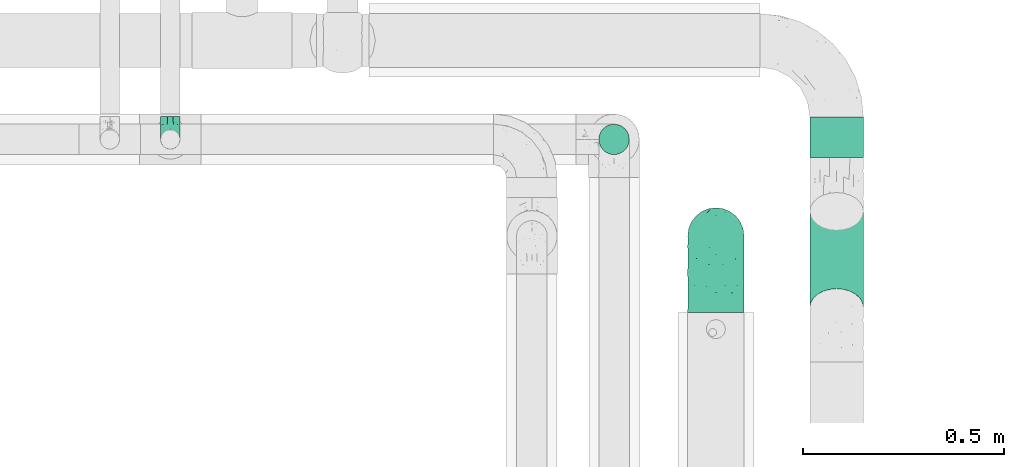
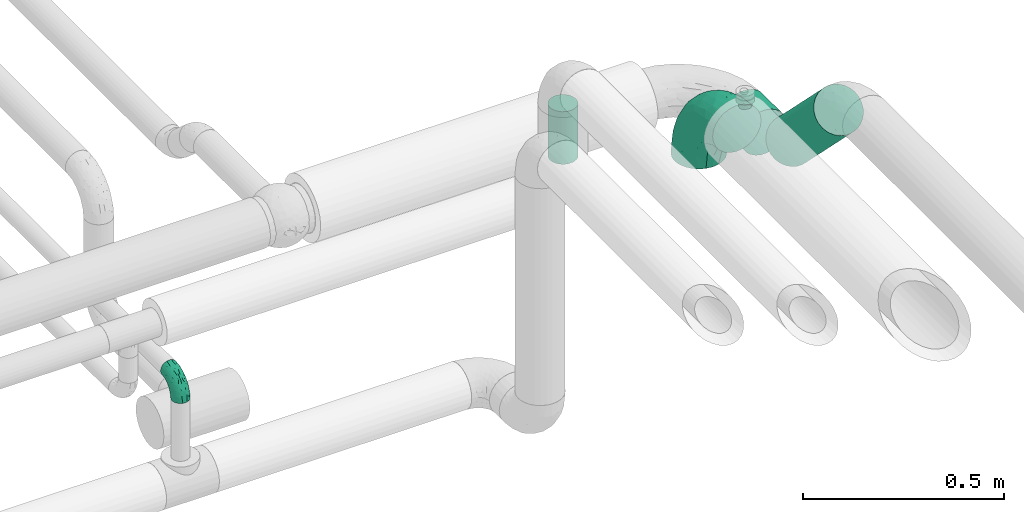
# One storey, part 558 of 827: 3 flow segments, 2 flow fittings.
"""IFC2X3 building model written with IfcOpenShell, lengths in millimetres."""

from ifc_helpers import new_model, entity, si_unit, converted_unit, derived_unit, direction, frame, origin, origin_2d_with_axis, place, context, subcontext, project, spatial, circle, extrude, faceted_brep, source, transform, mapped, material, type_object, type_shapes, element, save


model = new_model("IFC2X3")

# Units and contexts
model_context = context("Model", 3, precision=0.01, world=origin(), true_north=direction((6.12303176911189e-17, 1.0)))
body_context = subcontext(model_context, "Body", "Model", "MODEL_VIEW")
ifc_project = project(units=[si_unit("LENGTHUNIT", "METRE", prefix="MILLI"), si_unit("AREAUNIT", "SQUARE_METRE"), si_unit("VOLUMEUNIT", "CUBIC_METRE"), converted_unit("PLANEANGLEUNIT", "DEGREE", entity("IfcRatioMeasure", 0.0174532925199433), si_unit("PLANEANGLEUNIT", "RADIAN"), dimensions=[0, 0, 0, 0, 0, 0, 0]), si_unit("MASSUNIT", "GRAM", prefix="KILO"), derived_unit("MASSDENSITYUNIT", [(si_unit("MASSUNIT", "GRAM", prefix="KILO"), 1), (si_unit("LENGTHUNIT", "METRE"), -3)]), derived_unit("MOMENTOFINERTIAUNIT", [(si_unit("LENGTHUNIT", "METRE"), 4)]), si_unit("TIMEUNIT", "SECOND"), si_unit("FREQUENCYUNIT", "HERTZ"), si_unit("THERMODYNAMICTEMPERATUREUNIT", "DEGREE_CELSIUS"), derived_unit("THERMALTRANSMITTANCEUNIT", [(si_unit("MASSUNIT", "GRAM", prefix="KILO"), 1), (si_unit("THERMODYNAMICTEMPERATUREUNIT", "KELVIN"), -1), (si_unit("TIMEUNIT", "SECOND"), -3)]), derived_unit("VOLUMETRICFLOWRATEUNIT", [(si_unit("LENGTHUNIT", "METRE"), 3), (si_unit("TIMEUNIT", "SECOND"), -1)]), derived_unit("MASSFLOWRATEUNIT", [(si_unit("MASSUNIT", "GRAM", prefix="KILO"), 1), (si_unit("TIMEUNIT", "SECOND"), -1)]), derived_unit("ROTATIONALFREQUENCYUNIT", [(si_unit("TIMEUNIT", "SECOND"), -1)]), si_unit("ELECTRICCURRENTUNIT", "AMPERE"), si_unit("ELECTRICVOLTAGEUNIT", "VOLT"), si_unit("POWERUNIT", "WATT"), si_unit("FORCEUNIT", "NEWTON", prefix="KILO"), si_unit("ILLUMINANCEUNIT", "LUX"), si_unit("LUMINOUSFLUXUNIT", "LUMEN"), si_unit("LUMINOUSINTENSITYUNIT", "CANDELA"), derived_unit("USERDEFINED", [(si_unit("MASSUNIT", "GRAM", prefix="KILO"), -1), (si_unit("LENGTHUNIT", "METRE"), -2), (si_unit("TIMEUNIT", "SECOND"), 3), (si_unit("LUMINOUSFLUXUNIT", "LUMEN"), 1)]), derived_unit("LINEARVELOCITYUNIT", [(si_unit("LENGTHUNIT", "METRE"), 1), (si_unit("TIMEUNIT", "SECOND"), -1)]), si_unit("PRESSUREUNIT", "PASCAL"), derived_unit("USERDEFINED", [(si_unit("LENGTHUNIT", "METRE"), -2), (si_unit("MASSUNIT", "GRAM", prefix="KILO"), 1), (si_unit("TIMEUNIT", "SECOND"), -2)]), derived_unit("LINEARFORCEUNIT", [(si_unit("MASSUNIT", "GRAM", prefix="KILO"), 1), (si_unit("LENGTHUNIT", "METRE"), 1), (si_unit("TIMEUNIT", "SECOND"), -2), (si_unit("LENGTHUNIT", "METRE"), -1)]), derived_unit("PLANARFORCEUNIT", [(si_unit("MASSUNIT", "GRAM", prefix="KILO"), 1), (si_unit("LENGTHUNIT", "METRE"), 1), (si_unit("TIMEUNIT", "SECOND"), -2), (si_unit("LENGTHUNIT", "METRE"), -2)])], contexts=[model_context])

# Site, building, storey
site_placement = place(None, origin())
site = spatial("IfcSite", under=ifc_project, at=site_placement, CompositionType="ELEMENT")
building_placement = place(site_placement, origin())
building = spatial("IfcBuilding", under=site, at=building_placement, CompositionType="ELEMENT")
storey_placement = place(building_placement, frame((0.0, 0.0, 28200.0)))
storey = spatial("IfcBuildingStorey", under=building, at=storey_placement, Name="08", CompositionType="ELEMENT", Elevation=28200.0)

# Flow segments
pipe_segment_type_1 = type_object("IfcPipeSegmentType", PredefinedType="NOTDEFINED")
flow_segment_1_placement = place(storey_placement, frame((27351.94, 12025.46, 3031.9)))
element("IfcFlowSegment", 1, at=flow_segment_1_placement, inside=storey, type_object=pipe_segment_type_1, context=body_context, shape_type="SweptSolid", body=[
    extrude(circle(Radius=66.5, at=origin_2d_with_axis()), frame((68.1, 0.0, 68.1), z_axis=(0.0, 1.0, 0.0), x_axis=(-1.0, 0.0, 0.0)), (0.0, 0.0, 1.0), 100.109244825128),
])
flow_segment_2_placement = place(storey_placement, frame((27351.94, 11603.79, 3107.03)))
element("IfcFlowSegment", 2, at=flow_segment_2_placement, inside=storey, type_object=pipe_segment_type_1, context=body_context, shape_type="SweptSolid", body=[
    extrude(circle(Radius=66.5, at=origin_2d_with_axis()), frame((68.1, 48.62, 287.32), z_axis=(0.0, 0.707106781186515, -0.70710678118658), x_axis=(-1.0, 0.0, 0.0)), (0.0, 0.0, 1.0), 337.573593128828),
])
pipe_segment_type_2 = type_object("IfcPipeSegmentType", PredefinedType="NOTDEFINED")
flow_segment_3_placement = place(storey_placement, frame((26828.29, 12030.66, 3195.0)))
element("IfcFlowSegment", 3, at=flow_segment_3_placement, inside=storey, type_object=pipe_segment_type_2, context=body_context, shape_type="SweptSolid", body=[
    extrude(circle(Radius=37.75, at=origin_2d_with_axis()), frame((39.35, 39.35, 0.0), z_axis=(0.0, 0.0, 1.0), x_axis=(-1.0, 0.0, 0.0)), (0.0, 0.0, 1.0), 160.000000000016),
])

# Flow fittings
ifc_material = material()
pipe_fitting_type_1 = type_object("IfcPipeFittingType", Name="ADSK_1", PredefinedType="NOTDEFINED", material=ifc_material)
shared_shape_1 = source(origin(), body_context, "Body", "Brep", [
    faceted_brep([(-57.0, 12.07, -20.91), (-57.0, 6.25, -23.33), (-57.0, 0.0, -24.15), (-57.0, -6.25, -23.33), (-57.0, -12.08, -20.91), (-57.0, -17.08, -17.08), (-57.0, -20.91, -12.08), (-57.0, -23.33, -6.25), (-57.0, -24.15, 0.0), (-57.0, -23.33, 6.25), (-57.0, -20.91, 12.07), (-57.0, -17.08, 17.08), (-57.0, -12.08, 20.91), (-57.0, -6.25, 23.33), (-57.0, 0.0, 24.15), (-57.0, 6.25, 23.33), (-57.0, 12.07, 20.91), (-57.0, 17.08, 17.08), (-57.0, 20.91, 12.07), (-57.0, 23.33, 6.25), (-57.0, 24.15, 0.0), (-57.0, 23.33, -6.25), (-57.0, 20.91, -12.08), (-57.0, 17.08, -17.08), (0.0, 57.0, -24.15), (-6.25, 57.0, -23.33), (-12.07, 57.0, -20.91), (-17.08, 57.0, -17.08), (-20.91, 57.0, -12.08), (-23.33, 57.0, -6.25), (-24.15, 57.0, 0.0), (-23.33, 57.0, 6.25), (-20.91, 57.0, 12.07), (-17.08, 57.0, 17.08), (-12.07, 57.0, 20.91), (-6.25, 57.0, 23.33), (0.0, 57.0, 24.15), (6.25, 57.0, 23.33), (12.08, 57.0, 20.91), (17.08, 57.0, 17.08), (20.91, 57.0, 12.07), (23.33, 57.0, 6.25), (24.15, 57.0, 0.0), (23.33, 57.0, -6.25), (20.91, 57.0, -12.08), (17.08, 57.0, -17.08), (12.08, 57.0, -20.91), (6.25, 57.0, -23.33), (14.9, 21.14, 6.17), (13.61, 24.64, 12.48), (6.23, 8.95, 8.98), (-41.47, -21.06, 0.0), (-41.92, -18.38, 13.72), (-24.64, -13.61, 12.48), (-37.37, -13.24, 18.15), (-6.8, -4.93, 8.18), (-21.76, -15.19, 6.22), (-12.78, -9.18, 0.0), (-37.73, -20.51, 7.75), (-7.38, 7.38, 20.24), (-23.37, -4.26, 20.42), (-11.9, -3.19, 15.86), (-42.14, -8.7, 21.82), (13.24, 37.37, 18.15), (9.33, 23.53, 16.85), (4.26, 23.37, 20.42), (2.77, 10.92, 15.55), (-29.46, 0.91, 23.52), (-44.13, 20.56, 15.69), (-39.25, 26.33, 10.88), (-49.02, 22.92, 9.96), (-34.58, 23.87, 17.15), (-15.8, 6.8, 22.81), (-8.67, 20.47, 23.88), (-18.12, 12.9, 24.08), (-48.29, 14.92, 19.65), (-44.06, -2.85, 23.78), (-9.23, 48.95, 22.58), (-3.78, 42.74, 24.07), (-40.34, 4.26, 24.09), (-44.02, 26.14, 5.46), (-44.04, 9.88, 22.74), (-4.95, 16.87, 22.52), (-2.75, 1.43, 12.5), (-25.48, 40.98, 10.71), (20.51, 37.73, 7.75), (18.38, 41.92, 13.72), (8.7, 42.14, 21.82), (-25.95, -17.97, 0.0), (2.85, 44.06, 23.78), (21.06, 41.47, 0.0), (17.97, 25.95, 0.0), (-24.04, -9.27, 17.13), (-33.26, 33.26, 5.86), (-28.55, 40.57, 0.0), (-40.57, 28.55, 0.0), (-25.29, 47.19, 4.06), (-27.01, 31.1, 16.77), (-15.7, 43.95, 19.9), (-20.27, 45.22, 15.61), (-30.53, 31.98, 12.64), (-11.28, 38.33, 22.92), (-9.97, 27.88, 24.09), (-20.15, 30.26, 21.25), (-31.25, 11.75, 23.64), (-28.75, 7.23, 24.15), (-29.53, 18.06, 22.27), (-28.44, 24.21, 20.02), (-37.55, 17.7, 20.26), (-15.88, 29.25, 22.99), (-20.82, 20.82, 23.44), (-0.91, 29.46, 23.52), (-13.5, -7.67, 12.04), (1.49, 1.56, 5.16), (8.86, 10.35, 4.59), (0.38, -0.38, 0.0), (9.18, 12.78, 0.0), (-37.37, -13.24, -18.15), (8.86, 10.35, -4.59), (-45.22, 20.27, -15.61), (-43.95, 15.7, -19.9), (-38.33, 11.28, -22.92), (-48.95, 9.23, -22.58), (-47.19, 25.29, -4.06), (-33.26, 33.26, -5.86), (18.38, 41.92, -13.72), (-30.26, 20.15, -21.25), (2.85, 44.06, -23.78), (-4.26, 40.34, -24.09), (-40.98, 25.48, -10.71), (-41.92, -18.38, -13.72), (9.25, 23.5, -16.92), (4.26, 23.37, -20.42), (13.24, 37.37, -18.15), (-37.73, -20.51, -7.75), (-11.75, 31.25, -23.64), (-7.23, 28.75, -24.15), (-12.9, 18.12, -24.08), (8.7, 42.14, -21.82), (-44.06, -2.85, -23.78), (-6.8, 15.8, -22.81), (-20.47, 8.67, -23.88), (-24.64, -13.61, -12.48), (-42.74, 3.78, -24.07), (-18.06, 29.53, -22.27), (-24.21, 28.44, -20.02), (-27.88, 9.97, -24.09), (-31.1, 27.01, -16.77), (-26.14, 44.02, -5.46), (14.9, 21.14, -6.17), (20.51, 37.73, -7.75), (-9.88, 44.04, -22.74), (-20.56, 44.13, -15.69), (-21.76, -15.19, -6.22), (-13.5, -7.67, -12.04), (-24.14, -9.76, -16.74), (-11.9, -3.19, -15.86), (-14.92, 48.29, -19.65), (-23.37, -4.26, -20.42), (-0.91, 29.46, -23.52), (-26.33, 39.25, -10.88), (-23.87, 34.58, -17.15), (-42.14, -8.7, -21.82), (-22.92, 49.02, -9.96), (13.61, 24.64, -12.48), (-31.98, 30.53, -12.64), (-16.87, 4.95, -22.52), (-17.7, 37.55, -20.26), (-29.25, 15.88, -22.99), (-20.82, 20.82, -23.44), (-29.46, 0.91, -23.52), (-7.38, 7.38, -20.24), (2.77, 10.92, -15.55), (6.23, 8.95, -8.98), (-6.8, -4.93, -8.18), (-2.81, 1.41, -12.54), (1.49, 1.56, -5.16)], [[[0, 1, 2, 3, 4, 5, 6, 7, 8, 9, 10, 11, 12, 13, 14, 15, 16, 17, 18, 19, 20, 21, 22, 23]], [[24, 25, 26, 27, 28, 29, 30, 31, 32, 33, 34, 35, 36, 37, 38, 39, 40, 41, 42, 43, 44, 45, 46, 47]], [[48, 49, 50]], [[9, 8, 51]], [[52, 53, 54]], [[55, 56, 57]], [[10, 58, 52]], [[9, 58, 10]], [[59, 60, 61]], [[54, 12, 11]], [[54, 62, 12]], [[63, 39, 38]], [[64, 65, 66]], [[62, 60, 67]], [[68, 69, 70]], [[71, 69, 68]], [[72, 73, 74]], [[16, 75, 17]], [[13, 76, 14]], [[35, 77, 78]], [[14, 79, 15]], [[17, 68, 18]], [[14, 76, 79]], [[20, 19, 80]], [[70, 19, 18]], [[81, 15, 79]], [[15, 81, 16]], [[73, 72, 82]], [[66, 83, 50]], [[32, 31, 84]], [[85, 86, 49]], [[63, 87, 65]], [[56, 58, 88]], [[36, 89, 37]], [[85, 41, 40]], [[36, 35, 78]], [[90, 41, 85]], [[40, 39, 86]], [[12, 62, 13]], [[86, 85, 40]], [[48, 85, 49]], [[85, 91, 90]], [[87, 38, 37]], [[92, 60, 54]], [[80, 69, 93]], [[93, 94, 95]], [[10, 52, 11]], [[94, 96, 30]], [[97, 98, 99]], [[80, 93, 95]], [[100, 97, 84]], [[99, 98, 33]], [[101, 102, 78]], [[103, 101, 98]], [[96, 31, 30]], [[77, 98, 101]], [[77, 35, 34]], [[34, 33, 98]], [[9, 51, 58]], [[87, 63, 38]], [[104, 105, 74]], [[106, 103, 107]], [[106, 81, 104]], [[75, 68, 17]], [[108, 107, 71]], [[33, 32, 99]], [[109, 103, 110]], [[101, 109, 102]], [[89, 78, 111]], [[53, 52, 58]], [[54, 11, 52]], [[60, 62, 54]], [[88, 58, 51]], [[76, 62, 67]], [[53, 112, 92]], [[60, 59, 72]], [[39, 63, 86]], [[49, 86, 63]], [[89, 87, 37]], [[42, 41, 90]], [[111, 82, 65]], [[111, 65, 87]], [[65, 59, 66]], [[104, 81, 79]], [[75, 81, 108]], [[32, 84, 99]], [[97, 99, 84]], [[98, 97, 103]], [[106, 107, 108]], [[74, 102, 110]], [[111, 78, 102]], [[74, 110, 104]], [[74, 67, 72]], [[61, 92, 112]], [[66, 59, 61]], [[56, 53, 58]], [[66, 50, 49]], [[61, 112, 83]], [[66, 49, 64]], [[78, 89, 36]], [[87, 89, 111]], [[62, 76, 13]], [[79, 76, 67]], [[100, 93, 69]], [[96, 93, 84]], [[55, 113, 50]], [[113, 114, 50]], [[104, 79, 105]], [[106, 104, 110]], [[20, 80, 95]], [[85, 48, 91]], [[115, 114, 113]], [[116, 91, 48]], [[70, 80, 19]], [[93, 96, 94]], [[84, 31, 96]], [[103, 106, 110]], [[81, 106, 108]], [[103, 97, 107]], [[71, 107, 97]], [[71, 97, 100]], [[108, 71, 68]], [[79, 67, 105]], [[67, 74, 105]], [[115, 113, 57]], [[112, 56, 55]], [[56, 88, 57]], [[60, 72, 67]], [[82, 72, 59]], [[65, 82, 59]], [[82, 111, 73]], [[111, 102, 73]], [[102, 74, 73]], [[81, 75, 16]], [[68, 75, 108]], [[68, 70, 18]], [[80, 70, 69]], [[98, 77, 34]], [[78, 77, 101]], [[93, 100, 84]], [[71, 100, 69]], [[102, 109, 110]], [[101, 103, 109]], [[53, 92, 54]], [[61, 60, 92]], [[56, 112, 53]], [[83, 112, 55]], [[50, 83, 55]], [[61, 83, 66]], [[49, 63, 64]], [[65, 64, 63]], [[57, 113, 55]], [[114, 115, 116]], [[116, 48, 114]], [[48, 50, 114]], [[117, 5, 4]], [[116, 115, 118]], [[119, 120, 23]], [[121, 122, 120]], [[95, 123, 20]], [[0, 23, 120]], [[124, 95, 94]], [[125, 45, 44]], [[121, 120, 126]], [[24, 127, 128]], [[22, 21, 129]], [[0, 122, 1]], [[5, 117, 130]], [[131, 132, 133]], [[134, 88, 51]], [[135, 136, 137]], [[6, 5, 130]], [[46, 138, 47]], [[139, 3, 2]], [[140, 141, 137]], [[6, 134, 7]], [[134, 130, 142]], [[143, 2, 1]], [[144, 126, 145]], [[121, 146, 143]], [[147, 120, 119]], [[94, 148, 124]], [[149, 150, 91]], [[30, 29, 148]], [[151, 25, 128]], [[27, 152, 28]], [[134, 153, 88]], [[154, 155, 156]], [[27, 26, 157]], [[151, 26, 25]], [[155, 158, 156]], [[24, 47, 127]], [[1, 122, 143]], [[138, 132, 159]], [[160, 152, 161]], [[24, 128, 25]], [[46, 133, 138]], [[162, 117, 4]], [[148, 160, 124]], [[152, 160, 163]], [[154, 142, 155]], [[45, 125, 133]], [[133, 46, 45]], [[125, 164, 133]], [[51, 7, 134]], [[42, 90, 43]], [[165, 147, 129]], [[153, 134, 142]], [[43, 150, 44]], [[162, 4, 3]], [[141, 140, 166]], [[117, 162, 158]], [[163, 29, 28]], [[43, 90, 150]], [[123, 21, 20]], [[144, 151, 135]], [[157, 152, 27]], [[167, 145, 161]], [[23, 22, 119]], [[168, 126, 169]], [[121, 168, 146]], [[139, 143, 170]], [[142, 130, 117]], [[8, 7, 51]], [[134, 6, 130]], [[139, 162, 3]], [[170, 166, 158]], [[170, 158, 162]], [[158, 171, 156]], [[44, 150, 125]], [[91, 150, 90]], [[164, 125, 150]], [[132, 138, 133]], [[127, 138, 159]], [[131, 164, 172]], [[132, 171, 140]], [[135, 151, 128]], [[157, 151, 167]], [[22, 129, 119]], [[147, 119, 129]], [[120, 147, 126]], [[144, 145, 167]], [[137, 146, 169]], [[170, 143, 146]], [[137, 169, 135]], [[137, 159, 140]], [[171, 172, 156]], [[173, 174, 175]], [[156, 175, 154]], [[174, 57, 153]], [[132, 172, 171]], [[172, 164, 173]], [[143, 139, 2]], [[162, 139, 170]], [[138, 127, 47]], [[128, 127, 159]], [[165, 124, 160]], [[123, 124, 129]], [[149, 173, 164]], [[176, 174, 173]], [[135, 128, 136]], [[144, 135, 169]], [[150, 149, 164]], [[176, 118, 115]], [[149, 91, 116]], [[30, 148, 94]], [[163, 148, 29]], [[124, 123, 95]], [[129, 21, 123]], [[126, 144, 169]], [[151, 144, 167]], [[126, 147, 145]], [[161, 145, 147]], [[161, 147, 165]], [[167, 161, 152]], [[128, 159, 136]], [[159, 137, 136]], [[154, 153, 142]], [[132, 140, 159]], [[174, 176, 57]], [[57, 88, 153]], [[166, 140, 171]], [[158, 166, 171]], [[166, 170, 141]], [[170, 146, 141]], [[146, 137, 141]], [[151, 157, 26]], [[152, 157, 167]], [[152, 163, 28]], [[148, 163, 160]], [[120, 122, 0]], [[143, 122, 121]], [[124, 165, 129]], [[161, 165, 160]], [[146, 168, 169]], [[121, 126, 168]], [[142, 117, 155]], [[158, 155, 117]], [[175, 156, 172]], [[153, 154, 174]], [[173, 175, 172]], [[174, 154, 175]], [[164, 131, 133]], [[172, 132, 131]], [[176, 173, 118]], [[57, 176, 115]], [[173, 149, 118]], [[149, 116, 118]]]),
])
type_shapes(pipe_fitting_type_1, [shared_shape_1])
flow_fitting_1_placement = place(storey_placement, frame((25766.21, 12070.0, 2900.0), z_axis=(-1.0, 0.0, 0.0), x_axis=(0.0, 0.0, 1.0)))
element("IfcFlowFitting", 4, at=flow_fitting_1_placement, inside=storey, type_object=pipe_fitting_type_1, material=ifc_material, Name="ADSK_1", ObjectType="ADSK_1", context=body_context, shape_type="MappedRepresentation", body=[
    mapped(shared_shape_1, transform((0.0, 0.0, 0.0), scale=1.0)),
])
pipe_fitting_type_2 = type_object("IfcPipeFittingType", Name="ADSK_1", PredefinedType="NOTDEFINED", material=ifc_material)
shared_shape_2 = source(origin(), body_context, "Body", "Brep", [
    faceted_brep([(-190.0, 18.08, -67.47), (-190.0, 0.0, -69.85), (-190.0, -18.08, -67.47), (-190.0, -34.93, -60.49), (-190.0, -49.39, -49.39), (-190.0, -60.49, -34.93), (-190.0, -67.47, -18.08), (-190.0, -69.85, 0.0), (-190.0, -67.47, 18.08), (-190.0, -60.49, 34.92), (-190.0, -49.39, 49.39), (-190.0, -34.93, 60.49), (-190.0, -18.08, 67.47), (-190.0, 0.0, 69.85), (-190.0, 18.08, 67.47), (-190.0, 34.92, 60.49), (-190.0, 49.39, 49.39), (-190.0, 60.49, 34.92), (-190.0, 67.47, 18.08), (-190.0, 69.85, 0.0), (-190.0, 67.47, -18.08), (-190.0, 60.49, -34.93), (-190.0, 49.39, -49.39), (-190.0, 34.92, -60.49), (18.08, 190.0, -67.47), (0.0, 190.0, -69.85), (-18.08, 190.0, -67.47), (-34.92, 190.0, -60.49), (-49.39, 190.0, -49.39), (-60.49, 190.0, -34.93), (-67.47, 190.0, -18.08), (-69.85, 190.0, 0.0), (-67.47, 190.0, 18.08), (-60.49, 190.0, 34.92), (-49.39, 190.0, 49.39), (-34.92, 190.0, 60.49), (-18.08, 190.0, 67.47), (0.0, 190.0, 69.85), (18.08, 190.0, 67.47), (34.93, 190.0, 60.49), (49.39, 190.0, 49.39), (60.49, 190.0, 34.92), (67.47, 190.0, 18.08), (69.85, 190.0, 0.0), (67.47, 190.0, -18.08), (60.49, 190.0, -34.93), (49.39, 190.0, -49.39), (34.93, 190.0, -60.49), (-29.62, 146.98, 65.62), (-13.75, 135.37, 69.64), (-124.22, -36.33, 52.83), (-140.23, -52.18, 40.04), (-80.56, -34.09, 36.78), (-140.97, -24.01, 63.29), (-80.93, -8.05, 59.8), (-100.59, 5.62, 68.24), (-125.19, -57.65, 22.9), (-139.31, -64.86, 0.0), (-28.7, -8.91, 22.6), (-45.64, -26.06, 0.0), (-6.26, 6.26, 0.0), (-105.44, 36.89, 68.2), (-118.83, 43.56, 64.34), (-146.98, 29.62, 65.62), (-71.47, -38.86, 17.07), (-90.56, -50.07, 0.0), (-0.6, 27.02, 35.97), (-44.76, -2.31, 47.74), (-42.86, -12.1, 35.78), (-148.03, -7.38, 68.85), (-135.37, 13.75, 69.64), (-67.48, 159.11, 28.79), (36.32, 124.15, 52.82), (-38.8, 102.11, 68.2), (-24.59, 96.61, 69.85), (-81.73, 130.22, 21.92), (-65.15, 30.31, 68.68), (-27.72, 54.52, 66.49), (-44.98, 61.25, 69.74), (-75.73, 152.87, 0.0), (-159.11, 67.48, 28.79), (-130.22, 81.73, 21.92), (-152.87, 75.73, 0.0), (-76.65, 126.59, 35.57), (-101.51, 101.51, 25.92), (-96.74, 96.74, 38.75), (-144.94, 60.97, 45.11), (-159.57, 43.91, 56.71), (-119.38, 92.8, 0.0), (50.07, 90.56, 0.0), (57.42, 124.25, 22.84), (38.8, 71.6, 17.49), (64.86, 139.31, 0.0), (52.17, 140.21, 40.03), (33.37, 79.39, 36.99), (24.0, 140.95, 63.29), (8.03, 80.92, 59.81), (-82.61, -22.17, 50.94), (7.38, 148.03, 68.85), (-100.26, 79.14, 51.33), (-75.76, 96.1, 55.72), (-76.12, 111.95, 46.7), (-92.8, 119.38, 0.0), (-104.27, 104.27, 12.31), (10.07, 27.17, 16.15), (26.06, 45.64, 0.0), (-61.21, 144.14, 45.16), (-44.13, 158.15, 56.77), (-55.26, 120.41, 58.38), (9.95, 57.03, 48.64), (29.48, 90.08, 47.56), (-5.62, 100.59, 68.24), (-122.78, 54.24, 58.28), (-86.25, 73.26, 61.12), (-95.79, 24.47, 69.85), (-126.59, 76.65, 35.57), (-17.15, 26.56, 50.85), (-29.82, 29.82, 59.54), (-70.73, 11.02, 65.19), (-58.6, 94.58, 64.16), (-71.14, 66.1, 67.41), (-158.15, 44.13, -56.77), (33.37, 79.39, -36.99), (10.07, 27.17, -16.15), (-0.6, 27.02, -35.97), (-100.59, 5.62, -68.24), (-148.03, -7.38, -68.85), (-135.37, 13.75, -69.64), (-130.22, 81.73, -21.92), (-146.98, 29.62, -65.62), (-102.11, 38.8, -68.2), (-96.61, 24.59, -69.85), (-83.02, -24.86, -48.76), (-44.76, -2.31, -47.74), (-80.56, -34.09, -36.78), (-122.68, -57.24, -22.15), (-71.43, -38.87, -16.95), (-104.27, 104.27, -12.31), (-159.11, 67.48, -28.79), (-144.14, 61.21, -45.16), (7.38, 148.03, -68.85), (-13.75, 135.37, -69.64), (-79.14, 100.26, -51.33), (-96.1, 75.76, -55.72), (-111.95, 76.12, -46.7), (-80.93, -8.05, -59.8), (-124.22, -36.33, -52.83), (-140.23, -52.18, -40.04), (-24.47, 95.79, -69.85), (-36.89, 105.44, -68.2), (-150.18, -65.36, -13.92), (-43.56, 118.83, -64.34), (-29.62, 146.98, -65.62), (38.8, 71.6, -17.49), (-81.73, 130.22, -21.92), (-28.7, -8.91, -22.6), (-54.24, 122.78, -58.28), (-73.26, 86.25, -61.12), (-61.25, 44.98, -69.74), (-30.31, 65.15, -68.68), (-54.52, 27.72, -66.49), (-101.51, 101.51, -25.92), (-126.59, 76.65, -35.57), (-96.74, 96.74, -38.75), (-67.48, 159.11, -28.79), (-120.41, 55.26, -58.38), (-43.91, 159.57, -56.71), (24.0, 140.95, -63.29), (8.03, 80.92, -59.81), (-5.62, 100.59, -68.24), (-60.97, 144.94, -45.11), (36.32, 124.15, -52.82), (57.42, 124.25, -22.84), (52.17, 140.21, -40.03), (-140.97, -24.01, -63.29), (9.95, 57.03, -48.64), (-76.65, 126.59, -35.57), (22.84, 89.04, -52.94), (-11.03, 70.74, -65.2), (-29.82, 29.82, -59.54), (-94.58, 58.6, -64.16), (-66.1, 71.14, -67.41), (-31.42, -3.01, -36.09), (-13.88, 24.32, -46.86)], [[[0, 1, 2, 3, 4, 5, 6, 7, 8, 9, 10, 11, 12, 13, 14, 15, 16, 17, 18, 19, 20, 21, 22, 23]], [[24, 25, 26, 27, 28, 29, 30, 31, 32, 33, 34, 35, 36, 37, 38, 39, 40, 41, 42, 43, 44, 45, 46, 47]], [[36, 48, 49]], [[50, 51, 52]], [[53, 54, 55]], [[56, 9, 8]], [[8, 7, 57]], [[58, 59, 60]], [[51, 9, 56]], [[61, 62, 63]], [[59, 58, 64]], [[59, 64, 65]], [[11, 10, 50]], [[66, 67, 68]], [[50, 53, 11]], [[69, 70, 13]], [[71, 33, 32]], [[72, 40, 39]], [[73, 74, 49]], [[63, 15, 14]], [[13, 70, 14]], [[71, 32, 75]], [[12, 69, 13]], [[76, 77, 78]], [[32, 79, 75]], [[18, 80, 81]], [[63, 14, 70]], [[82, 19, 18]], [[83, 84, 85]], [[86, 16, 87]], [[82, 81, 88]], [[82, 18, 81]], [[15, 87, 16]], [[83, 71, 75]], [[52, 56, 64]], [[49, 37, 36]], [[89, 90, 91]], [[36, 35, 48]], [[42, 41, 90]], [[89, 92, 90]], [[11, 53, 12]], [[73, 78, 74]], [[65, 56, 57]], [[40, 72, 93]], [[94, 90, 93]], [[41, 40, 93]], [[72, 95, 96]], [[95, 39, 38]], [[8, 57, 56]], [[43, 42, 92]], [[67, 54, 97]], [[38, 37, 98]], [[99, 100, 101]], [[102, 75, 79]], [[51, 10, 9]], [[102, 88, 103]], [[31, 79, 32]], [[104, 60, 105]], [[106, 34, 33]], [[84, 103, 81]], [[91, 105, 89]], [[107, 35, 34]], [[106, 108, 107]], [[49, 48, 73]], [[104, 105, 91]], [[16, 86, 17]], [[58, 104, 66]], [[109, 110, 96]], [[111, 98, 49]], [[112, 113, 99]], [[92, 42, 90]], [[95, 72, 39]], [[70, 114, 61]], [[80, 18, 17]], [[101, 106, 83]], [[99, 86, 112]], [[115, 81, 80]], [[90, 94, 91]], [[94, 66, 104]], [[64, 58, 68]], [[56, 65, 64]], [[93, 72, 110]], [[90, 41, 93]], [[98, 95, 38]], [[111, 77, 96]], [[111, 96, 95]], [[67, 116, 117]], [[52, 51, 56]], [[50, 10, 51]], [[54, 53, 50]], [[69, 53, 55]], [[97, 52, 67]], [[118, 76, 55]], [[107, 48, 35]], [[73, 119, 120]], [[61, 63, 70]], [[63, 62, 87]], [[94, 104, 91]], [[58, 60, 104]], [[109, 66, 94]], [[67, 117, 54]], [[68, 67, 52]], [[116, 66, 109]], [[119, 48, 108]], [[73, 120, 78]], [[120, 61, 114]], [[78, 114, 76]], [[49, 98, 37]], [[95, 98, 111]], [[53, 69, 12]], [[70, 69, 55]], [[70, 55, 114]], [[120, 113, 62]], [[76, 114, 55]], [[120, 114, 78]], [[118, 55, 54]], [[76, 118, 77]], [[96, 77, 117]], [[111, 78, 77]], [[54, 117, 118]], [[77, 118, 117]], [[110, 109, 94]], [[116, 96, 117]], [[106, 107, 34]], [[48, 107, 108]], [[75, 84, 83]], [[106, 33, 71]], [[101, 83, 85]], [[106, 71, 83]], [[99, 101, 85]], [[108, 106, 101]], [[99, 85, 115]], [[113, 112, 62]], [[119, 113, 120]], [[100, 99, 113]], [[17, 86, 80]], [[115, 85, 84]], [[80, 86, 115]], [[99, 115, 86]], [[63, 87, 15]], [[86, 87, 112]], [[78, 111, 74]], [[111, 49, 74]], [[119, 100, 113]], [[101, 100, 108]], [[48, 119, 73]], [[119, 108, 100]], [[75, 102, 103]], [[115, 84, 81]], [[81, 103, 88]], [[75, 103, 84]], [[54, 50, 97]], [[52, 97, 50]], [[64, 68, 52]], [[66, 68, 58]], [[62, 61, 120]], [[87, 62, 112]], [[93, 110, 94]], [[96, 110, 72]], [[66, 116, 67]], [[96, 116, 109]], [[22, 121, 23]], [[122, 123, 124]], [[125, 126, 127]], [[20, 82, 128]], [[129, 130, 127]], [[130, 131, 127]], [[19, 82, 20]], [[132, 133, 134]], [[88, 128, 82]], [[135, 136, 65]], [[102, 137, 88]], [[138, 20, 128]], [[139, 22, 21]], [[140, 141, 25]], [[142, 143, 144]], [[145, 133, 132]], [[4, 146, 147]], [[141, 148, 149]], [[7, 6, 150]], [[138, 21, 20]], [[5, 4, 147]], [[149, 151, 152]], [[59, 65, 136]], [[122, 153, 123]], [[79, 30, 154]], [[134, 155, 136]], [[150, 65, 57]], [[156, 157, 142]], [[126, 2, 1]], [[134, 135, 147]], [[130, 158, 131]], [[159, 160, 158]], [[154, 161, 137]], [[0, 23, 129]], [[127, 1, 0]], [[162, 138, 128]], [[161, 163, 162]], [[30, 79, 31]], [[146, 4, 3]], [[154, 30, 164]], [[152, 27, 26]], [[165, 121, 139]], [[25, 24, 140]], [[25, 141, 26]], [[164, 30, 29]], [[27, 166, 28]], [[167, 168, 169]], [[141, 152, 26]], [[28, 170, 29]], [[47, 171, 167]], [[172, 89, 153]], [[59, 155, 60]], [[28, 166, 170]], [[46, 45, 173]], [[153, 89, 105]], [[105, 123, 153]], [[174, 146, 3]], [[171, 47, 46]], [[45, 44, 172]], [[7, 150, 57]], [[43, 92, 44]], [[122, 124, 175]], [[89, 172, 92]], [[171, 173, 122]], [[47, 167, 24]], [[173, 171, 46]], [[135, 150, 5]], [[0, 129, 127]], [[174, 3, 2]], [[79, 154, 102]], [[146, 174, 145]], [[44, 92, 172]], [[144, 139, 162]], [[142, 170, 156]], [[176, 154, 164]], [[105, 60, 123]], [[122, 172, 153]], [[45, 172, 173]], [[122, 173, 172]], [[167, 171, 177]], [[140, 167, 169]], [[177, 122, 175]], [[178, 159, 169]], [[134, 136, 135]], [[155, 59, 136]], [[134, 147, 146]], [[135, 5, 147]], [[126, 174, 2]], [[125, 160, 145]], [[125, 145, 174]], [[145, 179, 133]], [[121, 129, 23]], [[130, 180, 181]], [[149, 152, 141]], [[152, 151, 166]], [[60, 155, 123]], [[123, 155, 124]], [[182, 134, 133]], [[175, 179, 168]], [[183, 179, 175]], [[155, 182, 124]], [[180, 129, 165]], [[130, 181, 158]], [[181, 149, 148]], [[158, 148, 159]], [[127, 126, 1]], [[174, 126, 125]], [[167, 140, 24]], [[141, 140, 169]], [[141, 169, 148]], [[181, 157, 151]], [[159, 148, 169]], [[181, 148, 158]], [[178, 169, 168]], [[159, 178, 160]], [[145, 160, 179]], [[125, 158, 160]], [[168, 179, 178]], [[160, 178, 179]], [[175, 124, 183]], [[177, 175, 168]], [[139, 121, 22]], [[129, 121, 165]], [[128, 161, 162]], [[139, 21, 138]], [[144, 162, 163]], [[139, 138, 162]], [[142, 144, 163]], [[165, 139, 144]], [[142, 163, 176]], [[157, 156, 151]], [[180, 157, 181]], [[143, 142, 157]], [[29, 170, 164]], [[176, 163, 161]], [[164, 170, 176]], [[142, 176, 170]], [[152, 166, 27]], [[170, 166, 156]], [[158, 125, 131]], [[125, 127, 131]], [[180, 143, 157]], [[144, 143, 165]], [[129, 180, 130]], [[180, 165, 143]], [[128, 88, 137]], [[176, 161, 154]], [[154, 137, 102]], [[128, 137, 161]], [[5, 150, 6]], [[65, 150, 135]], [[134, 146, 132]], [[145, 132, 146]], [[134, 182, 155]], [[183, 182, 133]], [[151, 149, 181]], [[166, 151, 156]], [[182, 183, 124]], [[179, 183, 133]], [[167, 177, 168]], [[122, 177, 171]]]),
])
type_shapes(pipe_fitting_type_2, [shared_shape_2])
flow_fitting_2_placement = place(storey_placement, frame((27120.33, 11830.46, 3450.0), z_axis=(1.0, 0.0, 0.0), x_axis=(0.0, 0.0, 1.0)))
element("IfcFlowFitting", 5, at=flow_fitting_2_placement, inside=storey, type_object=pipe_fitting_type_2, material=ifc_material, Name="ADSK_1", ObjectType="ADSK_1", context=body_context, shape_type="MappedRepresentation", body=[
    mapped(shared_shape_2, transform((0.0, 0.0, 0.0), scale=1.0)),
])

save(model, "model.ifc")
